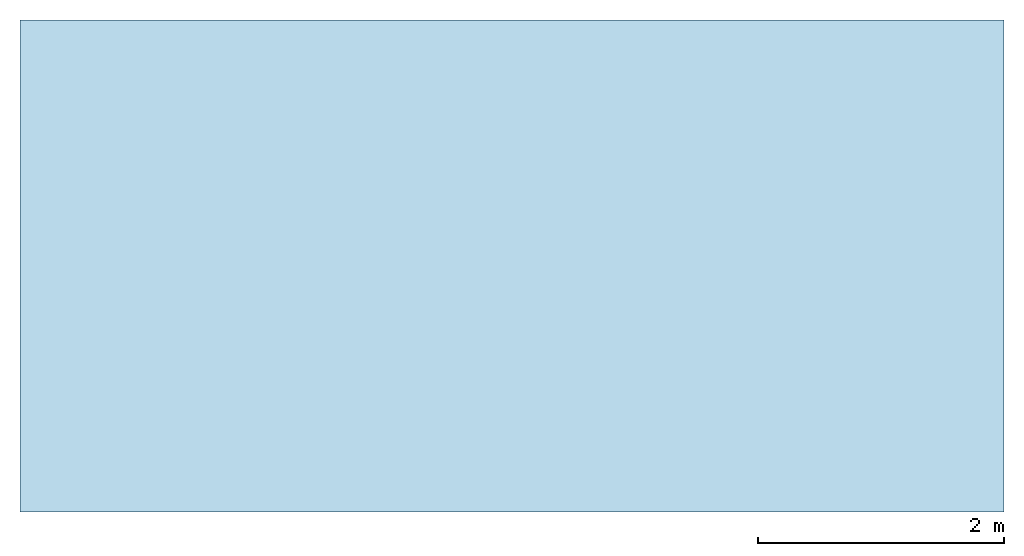
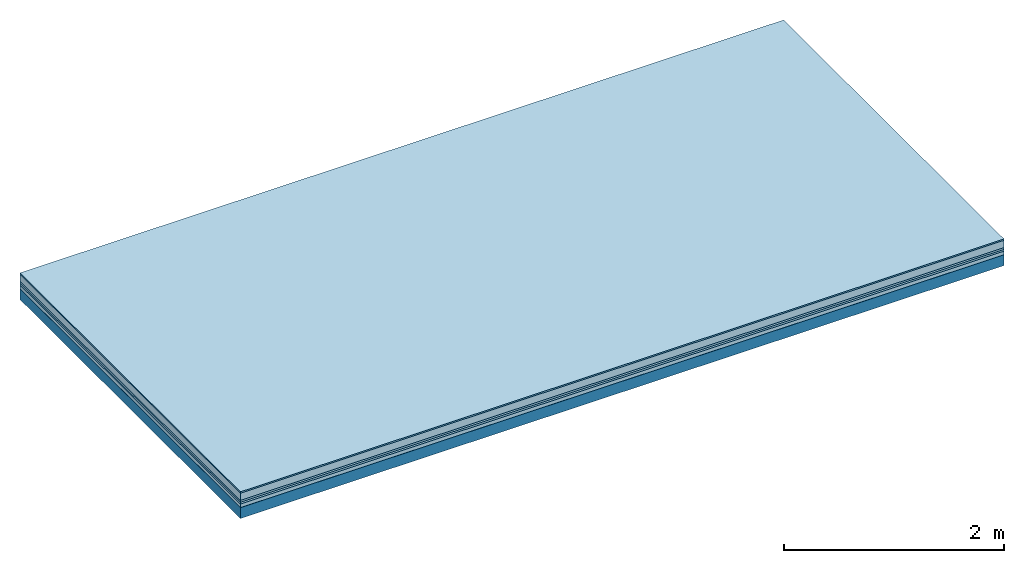
# One storey: 6 plates, 1 member, 1 element without a shape of its own.
"""IFC4 building model written with IfcOpenShell, lengths in metres."""

from ifc_helpers import new_model, si_unit, derived_unit, direction, frame, frame_2d, origin, origin_with_axes, place, context, project, spatial, rectangle, extrude, material, layer, layer_set, type_object, element, aggregate, save


model = new_model("IFC4")

# Units and contexts
plan_context = context("Plan", 3, precision=1e-05, world=origin(), true_north=direction((0.0, 1.0)))
model_context = context("Model", 3, precision=1e-05, world=origin(), true_north=direction((0.0, 1.0)))
ifc_project = project(units=[si_unit("LENGTHUNIT", "METRE"), derived_unit("SOUNDPRESSUREUNIT", [(si_unit("PRESSUREUNIT", "PASCAL", prefix="MICRO"), 0)]), si_unit("ENERGYUNIT", "JOULE", prefix="MEGA"), si_unit("MASSUNIT", "GRAM", prefix="KILO"), derived_unit("THERMALTRANSMITTANCEUNIT", [(si_unit("POWERUNIT", "WATT"), 1), (si_unit("AREAUNIT", "SQUARE_METRE"), -1), (si_unit("THERMODYNAMICTEMPERATUREUNIT", "KELVIN"), -1)]), derived_unit("AREADENSITYUNIT", [(si_unit("MASSUNIT", "GRAM", prefix="KILO"), 1), (si_unit("AREAUNIT", "SQUARE_METRE"), -1)]), derived_unit("USERDEFINED", [(si_unit("ENERGYUNIT", "JOULE", prefix="MEGA"), 1), (si_unit("AREAUNIT", "SQUARE_METRE"), -1)])], contexts=[plan_context, model_context])

# Site, building, storey
site = spatial("IfcSite", under=ifc_project)
building_placement = place(None, origin())
building = spatial("IfcBuilding", under=site, at=building_placement)
storey_placement = place(building_placement, origin())
storey = spatial("IfcBuildingStorey", under=building, at=storey_placement)

# Slab, member, plates
ifc_material_1 = material(Category="11.013")
ifc_layer_1 = layer(ifc_material_1, 0.015, Name="Flooring")
ifc_material_2 = material(Name="Cement screed", Category="04.006")
ifc_layer_2 = layer(ifc_material_2, 0.08, Name="On-material")
ifc_material_3 = material(Name="Wood fiber generic product", Category="10.009")
ifc_layer_3 = layer(ifc_material_3, 0.02, Name="Impact sound insulation")
ifc_material_4 = material()
ifc_layer_4 = layer(ifc_material_4, 0.02, Name="Additional insulation")
ifc_material_5 = material(Name="Cement panels, glued on sub-floor", Category="02.007")
ifc_layer_5 = layer(ifc_material_5, 0.04, Name="on Supporting structure")
ifc_material_6 = material(Name="protection", Category="09.007")
ifc_layer_6 = layer(ifc_material_6, 0.0005, Name="Sub-floor")
ifc_material_7 = material(Name="no composite action")
ifc_layer_7 = layer(ifc_material_7, 0.0, Name="Bond")
ifc_layer_8 = layer(None, 0.12, Name="Supporting structure")
ifc_layer_set = layer_set([ifc_layer_1, ifc_layer_2, ifc_layer_3, ifc_layer_4, ifc_layer_5, ifc_layer_6, ifc_layer_7, ifc_layer_8])
slab_type = type_object("IfcSlabType", Name="A2087", PredefinedType="NOTDEFINED", material=ifc_layer_set)
slab_placement = place(None, frame((0.0, 0.0, 0.0), z_axis=(0.0, 0.0, -1.0), x_axis=(1.0, 0.0, 0.0)))
slab = element("IfcSlab", 1, at=slab_placement, inside=storey, type_object=slab_type, material=ifc_layer_set, Name="Slab #1")
ifc_material_8 = material(Name="Solid timber panel")
member_placement = place(slab_placement, origin())
member = element("IfcMember", 2, at=member_placement, material=ifc_material_8, Name="Supporting structure", context=plan_context, shape_type="SweptSolid", body=[
    extrude(rectangle(XDim=1.0, YDim=0.12, at=frame_2d((0.5, 0.06), x_axis=(1.0, 0.0))), frame((0.0, 4.0, 0.1755), z_axis=(0.0, -1.0, 0.0), x_axis=(1.0, 0.0, 0.0)), (0.0, 0.0, 1.0), 4.0),
    extrude(rectangle(XDim=1.0, YDim=0.12, at=frame_2d((0.5, 0.06), x_axis=(1.0, 0.0))), frame((1.0, 4.0, 0.1755), z_axis=(0.0, -1.0, 0.0), x_axis=(1.0, 0.0, 0.0)), (0.0, 0.0, 1.0), 4.0),
    extrude(rectangle(XDim=1.0, YDim=0.12, at=frame_2d((0.5, 0.06), x_axis=(1.0, 0.0))), frame((2.0, 4.0, 0.1755), z_axis=(0.0, -1.0, 0.0), x_axis=(1.0, 0.0, 0.0)), (0.0, 0.0, 1.0), 4.0),
    extrude(rectangle(XDim=1.0, YDim=0.12, at=frame_2d((0.5, 0.06), x_axis=(1.0, 0.0))), frame((3.0, 4.0, 0.1755), z_axis=(0.0, -1.0, 0.0), x_axis=(1.0, 0.0, 0.0)), (0.0, 0.0, 1.0), 4.0),
    extrude(rectangle(XDim=1.0, YDim=0.12, at=frame_2d((0.5, 0.06), x_axis=(1.0, 0.0))), frame((4.0, 4.0, 0.1755), z_axis=(0.0, -1.0, 0.0), x_axis=(1.0, 0.0, 0.0)), (0.0, 0.0, 1.0), 4.0),
    extrude(rectangle(XDim=1.0, YDim=0.12, at=frame_2d((0.5, 0.06), x_axis=(1.0, 0.0))), frame((5.0, 4.0, 0.1755), z_axis=(0.0, -1.0, 0.0), x_axis=(1.0, 0.0, 0.0)), (0.0, 0.0, 1.0), 4.0),
    extrude(rectangle(XDim=1.0, YDim=0.12, at=frame_2d((0.5, 0.06), x_axis=(1.0, 0.0))), frame((6.0, 4.0, 0.1755), z_axis=(0.0, -1.0, 0.0), x_axis=(1.0, 0.0, 0.0)), (0.0, 0.0, 1.0), 4.0),
    extrude(rectangle(XDim=1.0, YDim=0.12, at=frame_2d((0.5, 0.06), x_axis=(1.0, 0.0))), frame((7.0, 4.0, 0.1755), z_axis=(0.0, -1.0, 0.0), x_axis=(1.0, 0.0, 0.0)), (0.0, 0.0, 1.0), 4.0),
])
plate_1_placement = place(slab_placement, origin())
plate_1 = element("IfcPlate", 3, at=plate_1_placement, material=ifc_material_1, Name="Flooring", context=plan_context, shape_type="SweptSolid", body=[
    extrude(rectangle(XDim=8.0, YDim=4.0, at=frame_2d((4.0, 2.0), x_axis=(1.0, 0.0))), origin_with_axes(), (0.0, 0.0, 1.0), 0.015),
])
plate_2_placement = place(slab_placement, origin())
plate_2 = element("IfcPlate", 4, at=plate_2_placement, material=ifc_material_2, Name="On-material", context=plan_context, shape_type="SweptSolid", body=[
    extrude(rectangle(XDim=8.0, YDim=4.0, at=frame_2d((4.0, 2.0), x_axis=(1.0, 0.0))), frame((0.0, 0.0, 0.015), z_axis=(0.0, 0.0, 1.0), x_axis=(1.0, 0.0, 0.0)), (0.0, 0.0, 1.0), 0.08),
])
plate_3_placement = place(slab_placement, origin())
plate_3 = element("IfcPlate", 5, at=plate_3_placement, material=ifc_material_3, Name="Impact sound insulation", context=plan_context, shape_type="SweptSolid", body=[
    extrude(rectangle(XDim=8.0, YDim=4.0, at=frame_2d((4.0, 2.0), x_axis=(1.0, 0.0))), frame((0.0, 0.0, 0.095), z_axis=(0.0, 0.0, 1.0), x_axis=(1.0, 0.0, 0.0)), (0.0, 0.0, 1.0), 0.02),
])
plate_4_placement = place(slab_placement, origin())
plate_4 = element("IfcPlate", 6, at=plate_4_placement, material=ifc_material_4, Name="Additional insulation", context=plan_context, shape_type="SweptSolid", body=[
    extrude(rectangle(XDim=8.0, YDim=4.0, at=frame_2d((4.0, 2.0), x_axis=(1.0, 0.0))), frame((0.0, 0.0, 0.115), z_axis=(0.0, 0.0, 1.0), x_axis=(1.0, 0.0, 0.0)), (0.0, 0.0, 1.0), 0.02),
])
plate_5_placement = place(slab_placement, origin())
plate_5 = element("IfcPlate", 7, at=plate_5_placement, material=ifc_material_5, Name="on Supporting structure", context=plan_context, shape_type="SweptSolid", body=[
    extrude(rectangle(XDim=8.0, YDim=4.0, at=frame_2d((4.0, 2.0), x_axis=(1.0, 0.0))), frame((0.0, 0.0, 0.135), z_axis=(0.0, 0.0, 1.0), x_axis=(1.0, 0.0, 0.0)), (0.0, 0.0, 1.0), 0.04),
])
plate_6_placement = place(slab_placement, origin())
plate_6 = element("IfcPlate", 8, at=plate_6_placement, material=ifc_material_6, Name="Sub-floor", context=plan_context, shape_type="SweptSolid", body=[
    extrude(rectangle(XDim=8.0, YDim=4.0, at=frame_2d((4.0, 2.0), x_axis=(1.0, 0.0))), frame((0.0, 0.0, 0.175), z_axis=(0.0, 0.0, 1.0), x_axis=(1.0, 0.0, 0.0)), (0.0, 0.0, 1.0), 0.0005),
])
aggregate(slab, [plate_1, plate_2, plate_3, plate_4, plate_5, plate_6, member])

save(model, "model.ifc")
